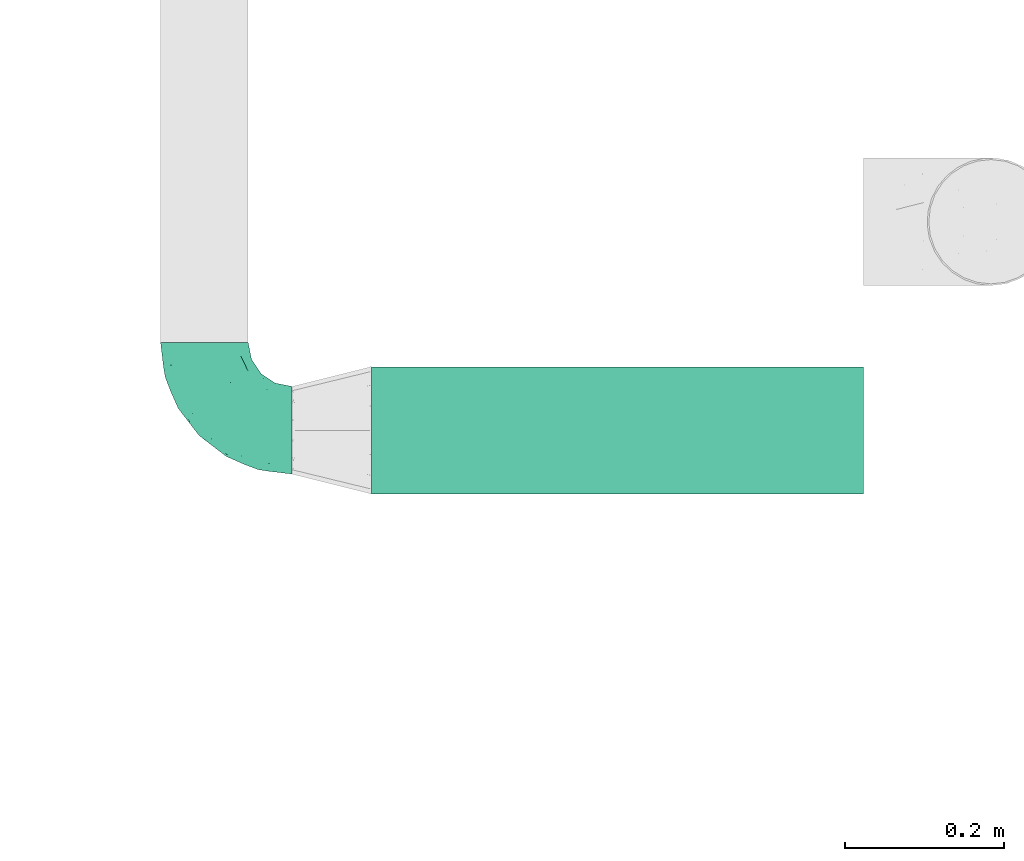
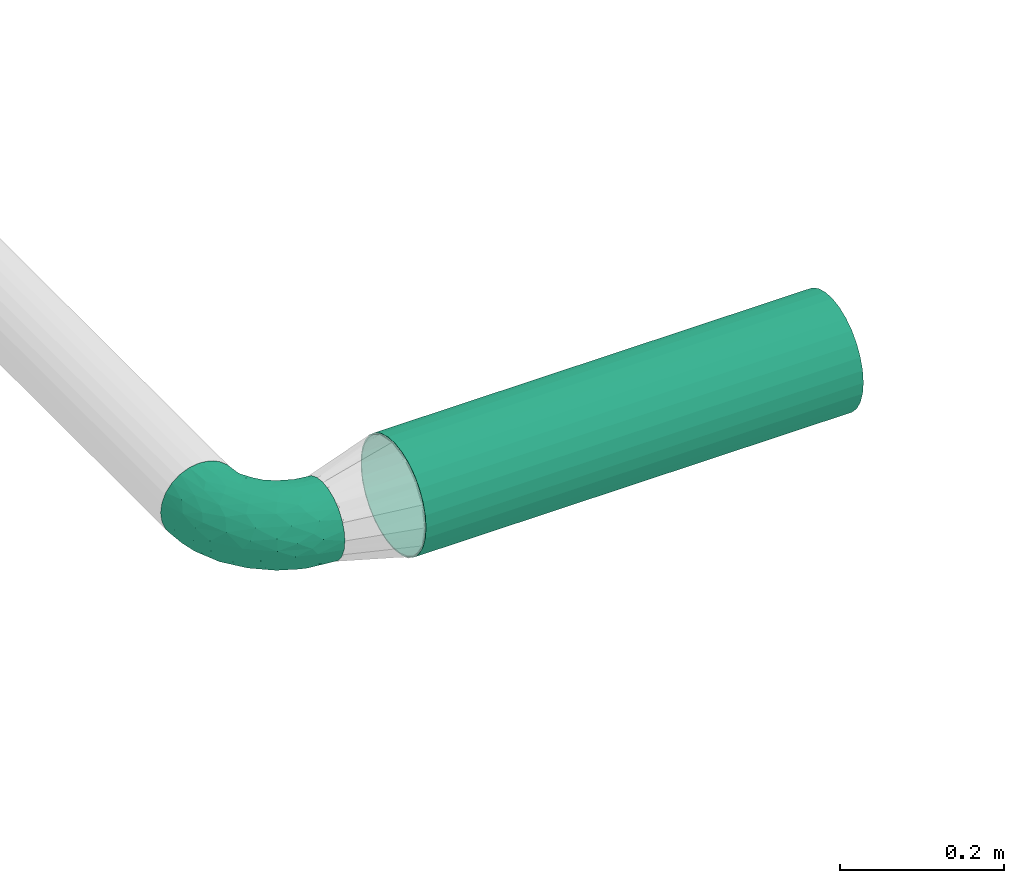
# One storey, part 107 of 123: 1 flow fitting, 1 flow segment.
"""IFC2X3 building model written with IfcOpenShell, lengths in millimetres."""

from ifc_helpers import new_model, entity, si_unit, converted_unit, derived_unit, direction, frame, origin_with_axes, origin_2d_with_axis, place, context, subcontext, project, spatial, hollow_circle, extrude, open_shell, surface_model, source, transform, mapped, material, layer, layer_set, layer_usage, type_object, element, save


model = new_model("IFC2X3")

# Units and contexts
model_context = context("Model", 3, precision=1e-05, world=origin_with_axes(), true_north=direction((0.0, 1.0)))
body_context = subcontext(model_context, "Body", "Model", "MODEL_VIEW")
ifc_project = project(units=[si_unit("AREAUNIT", "SQUARE_METRE"), si_unit("VOLUMEUNIT", "CUBIC_METRE", prefix="DECI"), si_unit("TIMEUNIT", "SECOND"), si_unit("THERMODYNAMICTEMPERATUREUNIT", "DEGREE_CELSIUS"), si_unit("PRESSUREUNIT", "PASCAL"), si_unit("MASSUNIT", "GRAM", prefix="KILO"), si_unit("LENGTHUNIT", "METRE", prefix="MILLI"), si_unit("POWERUNIT", "WATT"), si_unit("ELECTRICCURRENTUNIT", "AMPERE"), si_unit("ELECTRICVOLTAGEUNIT", "VOLT"), derived_unit("VOLUMETRICFLOWRATEUNIT", [(si_unit("VOLUMEUNIT", "CUBIC_METRE", prefix="DECI"), 1), (si_unit("TIMEUNIT", "SECOND"), -1)]), derived_unit("LINEARVELOCITYUNIT", [(si_unit("LENGTHUNIT", "METRE"), 1), (si_unit("TIMEUNIT", "SECOND"), -1)]), derived_unit("MASSDENSITYUNIT", [(si_unit("MASSUNIT", "GRAM", prefix="KILO"), 1), (si_unit("VOLUMEUNIT", "CUBIC_METRE"), -1)]), converted_unit("PLANEANGLEUNIT", "DEGREE", entity("IfcRatioMeasure", 0.01745), si_unit("PLANEANGLEUNIT", "RADIAN"), dimensions=[0, 0, 0, 0, 0, 0, 0])], contexts=[model_context])

# Site, building, storey
site_placement = place(None, origin_with_axes())
site = spatial("IfcSite", under=ifc_project, at=site_placement, CompositionType="ELEMENT")
building_placement = place(site_placement, origin_with_axes())
building = spatial("IfcBuilding", under=site, at=building_placement, Name="mc-building", CompositionType="ELEMENT")
storey_placement = place(building_placement, origin_with_axes())
storey = spatial("IfcBuildingStorey", under=building, at=storey_placement, Name="1. Korrus", CompositionType="ELEMENT", Elevation=0.0)

# Flow fitting
duct_fitting_type = type_object("IfcDuctFittingType", Name="BU", PredefinedType="BEND")
shared_shape_1 = source(origin_with_axes(), body_context, "Body", "SurfaceModel", [
    surface_model("IfcShellBasedSurfaceModel", [(-110.0, 0.0, -55.0), (-110.0, -14.23505, -53.12592), (-110.0, 14.23505, -53.12592), (-110.0, 53.12592, 14.23505), (-110.0, 27.5, -47.63139), (-110.0, 38.89087, -38.89087), (-110.0, -55.0, 0.0), (-110.0, -53.12592, 14.23505), (-110.0, -38.89087, -38.89087), (-110.0, -27.5, -47.63139), (-110.0, -53.12592, -14.23505), (-110.0, -47.63139, -27.5), (-110.0, -14.23505, 53.12592), (-110.0, 14.23505, 53.12592), (-110.0, 27.5, 47.63139), (-110.0, -47.63139, 27.5), (-110.0, -38.89087, 38.89087), (-110.0, -27.5, 47.63139), (-110.0, 0.0, 55.0), (-110.0, 55.0, 0.0), (-110.0, 53.12592, -14.23505), (-110.0, 47.63139, -27.5), (-110.0, 47.63139, 27.5), (-110.0, 38.89087, 38.89087), (-14.23505, 110.0, -53.12592), (-55.0, 110.0, 0.0), (0.0, 110.0, -55.0), (-27.5, 110.0, -47.63139), (-38.89087, 110.0, -38.89087), (-47.63139, 110.0, -27.5), (38.89087, 110.0, -38.89087), (53.12592, 110.0, 14.23505), (27.5, 110.0, -47.63139), (14.23505, 110.0, -53.12592), (47.63139, 110.0, -27.5), (53.12592, 110.0, -14.23505), (55.0, 110.0, 0.0), (-53.12592, 110.0, -14.23505), (-53.12592, 110.0, 14.23505), (-47.63139, 110.0, 27.5), (-38.89087, 110.0, 38.89087), (-27.5, 110.0, 47.63139), (0.0, 110.0, 55.0), (-14.23505, 110.0, 53.12592), (38.89087, 110.0, 38.89087), (47.63139, 110.0, 27.5), (27.5, 110.0, 47.63139), (14.23505, 110.0, 53.12592), (-64.21732, 48.68956, 43.63444), (-76.6405, 38.18013, 45.55988), (-60.44912, 32.56953, 51.94617), (-76.00813, 5.38378, 55.0), (-90.15553, 11.94394, 54.09138), (-78.5998, 26.77405, 50.81338), (-70.18771, 18.55163, 54.03432), (-75.55424, 54.2118, 32.41257), (-93.27622, 45.77614, 33.48188), (-96.12334, 22.13664, 50.81337), (-21.00813, 45.34362, 55.0), (-18.36258, 70.48427, 54.04484), (-32.04182, 59.64019, 52.24446), (-63.88653, 74.77858, 17.99134), (-74.66383, 63.08407, 19.92123), (-63.60674, 66.07878, 29.97482), (-99.597, 52.72185, 18.52927), (-93.11138, 56.59448, 10.50359), (-98.21577, 57.34403, 0.0), (-53.42855, 92.60092, 21.04759), (-88.54852, 54.8376, 21.04759), (-11.86161, 90.23965, 54.10313), (-5.38378, 76.00813, 55.0), (-57.34403, 98.21577, 0.0), (-56.64619, 93.12774, 10.22088), (-45.34362, 21.00813, 55.0), (-44.60838, 44.60838, 52.13415), (-92.68484, 35.46673, 43.63443), (-22.25266, 95.40765, 50.81337), (-35.97783, 90.61597, 43.63443), (-43.70931, 69.58671, 44.47149), (-27.23711, 77.39884, 50.81337), (-57.2828, 79.3123, 24.9774), (-58.67786, 84.31125, 16.04456), (-82.93277, 60.36161, 12.91784), (-49.88337, 54.51816, 47.224), (-74.57753, 66.83759, 9.55742), (-45.35812, 94.97281, 33.48188), (-59.18663, 88.95241, 0.0), (-51.517, 78.6292, 33.48188), (-65.14788, 80.03077, 0.0), (-56.45322, 62.06476, 39.63545), (-88.95241, 59.18663, 0.0), (-71.10913, 71.10913, 0.0), (-80.03077, 65.14788, 0.0), (-94.9309, 45.36788, -33.48188), (-93.11358, 56.60141, -10.46614), (-99.64997, 52.79499, -18.30015), (-90.20425, 36.08686, -43.63443), (-79.99933, 46.56772, -37.92748), (-76.00813, 5.38378, -55.0), (-72.75364, 19.68651, -53.60527), (-45.34362, 21.00813, -55.0), (-21.91957, 65.12078, -53.85897), (-5.38378, 76.00813, -55.0), (-21.00813, 45.34362, -55.0), (-35.41876, 92.89265, -43.63443), (-91.10309, 11.02766, -54.21832), (-45.77614, 93.27622, -33.48188), (-90.50474, 23.21022, -50.81337), (-70.92854, 33.31794, -49.51754), (-78.52933, 63.35627, -11.73997), (-24.91508, 84.05606, -50.81337), (-88.78941, 54.74452, -21.04759), (-69.59921, 57.34866, -33.48187), (-73.36422, 62.46673, -22.94182), (-63.49062, 67.59111, -28.46929), (-56.59448, 93.11138, -10.50359), (-54.8376, 88.54852, -21.04759), (-54.10679, 75.85581, -32.31867), (-57.75956, 31.09612, -52.80882), (-52.72185, 99.597, -18.52927), (-12.62913, 89.46304, -53.99097), (-34.46825, 66.46123, -50.04329), (-43.9837, 43.9837, -52.42279), (-65.78527, 72.58348, -17.68796), (-70.34468, 43.65295, -44.21951), (-57.47001, 51.99467, -44.91465), (-60.72547, 82.29174, -12.88567), (-42.34915, 74.24548, -43.63444), (-57.25194, 63.5016, -38.08211), (-80.95344, 53.56991, -29.32027), (-52.32891, 4.55257, -54.0482), (32.52942, 47.13398, -30.48571), (14.88266, 20.92917, -33.7947), (14.95561, 36.05775, -42.26543), (30.24048, 70.09027, -41.7461), (19.3559, 65.35825, -48.00507), (-70.35075, -46.44478, -19.5952), (-47.13398, -32.52942, -30.48571), (-28.49299, -30.5778, -16.4009), (-4.55257, 52.32891, -54.0482), (-22.4954, 22.4954, -53.25347), (-75.47368, -11.22546, -52.60718), (-81.32209, -51.5606, -9.98467), (-80.81763, -41.84862, -32.14655), (-70.09027, -30.24048, -41.7461), (-36.05774, -14.95561, -42.26543), (-9.15831, -10.852, -27.8997), (-65.35825, -19.3559, -48.00507), (11.22546, 75.47368, -52.60718), (3.94376, 43.9333, -50.53315), (-13.39742, 13.39743, -48.13058), (-43.9333, -3.94376, -50.53315), (49.37776, 67.29486, 0.0), (41.8609, 47.82256, -9.92641), (50.20582, 74.51695, -9.9731), (18.93131, 11.7156, -17.56239), (-27.5, -32.89419, 0.0), (-1.23348, -12.25375, -12.18106), (41.84862, 80.81763, -32.14655), (35.70604, 41.31408, -20.38235), (46.44478, 70.35075, -19.5952), (32.89419, 27.5, 0.0), (6.67262, -6.67262, 0.0), (-67.29486, -49.37776, 0.0), (-50.36265, -42.95545, -9.51562), (-5.47251, 5.47251, -39.92906), (-70.35075, -46.44478, 19.5952), (-74.51695, -50.20582, 9.9731), (-41.31407, -35.70604, 20.38235), (-47.13398, -32.52942, 30.48571), (-80.81763, -41.84862, 32.14655), (-4.55257, 52.32891, 54.0482), (11.22546, 75.47368, 52.60718), (-43.9333, -3.94376, 50.53315), (-65.35825, -19.3559, 48.00507), (-36.05774, -14.95561, 42.26543), (-70.09027, -30.24048, 41.7461), (-11.7156, -18.93131, 17.56239), (30.5778, 28.49299, 16.4009), (12.25375, 1.23348, 12.18106), (51.5606, 81.32209, 9.98467), (42.95545, 50.36265, 9.51562), (-75.47368, -11.22546, 52.60718), (-52.32891, 4.55257, 54.0482), (3.94376, 43.9333, 50.53315), (-22.4954, 22.4954, 53.25347), (-13.39742, 13.39743, 48.13058), (10.852, 9.15831, 27.8997), (-20.92916, -14.88266, 33.79469), (-47.82256, -41.8609, 9.92641), (32.52942, 47.13398, 30.48571), (46.44478, 70.35075, 19.5952), (41.84862, 80.81763, 32.14655), (30.24048, 70.09027, 41.7461), (19.3559, 65.35825, 48.00507), (14.95561, 36.05775, 42.26543), (-5.47251, 5.47251, 39.92906)], [open_shell([[[0, 1, 2]], [[2, 3, 4]], [[4, 3, 5]], [[2, 6, 7]], [[8, 6, 9]], [[1, 9, 6]], [[10, 6, 11]], [[8, 11, 6]], [[6, 2, 1]], [[12, 13, 14]], [[15, 2, 7]], [[16, 17, 2]], [[2, 17, 12]], [[12, 18, 13]], [[19, 20, 3]], [[5, 3, 21]], [[20, 21, 3]], [[22, 3, 2]], [[23, 22, 2]], [[12, 14, 2]], [[2, 14, 23]], [[15, 16, 2]], [[24, 25, 26]], [[27, 25, 24]], [[25, 28, 29]], [[28, 25, 27]], [[30, 26, 31]], [[26, 30, 32]], [[32, 33, 26]], [[34, 31, 35]], [[31, 34, 30]], [[35, 31, 36]], [[29, 37, 25]], [[38, 39, 26]], [[39, 40, 26]], [[41, 42, 40]], [[42, 26, 40]], [[42, 41, 43]], [[26, 44, 45]], [[31, 26, 45]], [[26, 46, 44]], [[47, 46, 26]], [[42, 47, 26]], [[25, 38, 26]], [[48, 49, 50]], [[18, 51, 52]], [[53, 54, 50]], [[55, 56, 49]], [[56, 22, 23]], [[13, 57, 14]], [[58, 59, 60]], [[61, 62, 63]], [[3, 64, 65]], [[53, 52, 54]], [[3, 65, 66]], [[67, 39, 38]], [[56, 68, 64]], [[65, 64, 68]], [[69, 59, 70]], [[38, 71, 72]], [[73, 58, 74]], [[75, 49, 56]], [[76, 69, 43]], [[53, 57, 52]], [[77, 78, 79]], [[41, 76, 43]], [[43, 69, 42]], [[55, 68, 56]], [[23, 14, 75]], [[76, 77, 79]], [[80, 67, 81]], [[62, 82, 68]], [[60, 78, 83]], [[62, 84, 82]], [[85, 77, 40]], [[81, 67, 72]], [[86, 72, 71]], [[87, 85, 67]], [[61, 81, 88]], [[77, 41, 40]], [[78, 77, 87]], [[23, 75, 56]], [[83, 89, 48]], [[85, 40, 39]], [[62, 68, 55]], [[89, 87, 63]], [[83, 48, 50]], [[57, 75, 14]], [[49, 75, 53]], [[67, 85, 39]], [[87, 77, 85]], [[63, 62, 55]], [[89, 55, 48]], [[80, 63, 87]], [[66, 65, 90]], [[66, 19, 3]], [[84, 91, 92]], [[92, 90, 82]], [[65, 82, 90]], [[61, 84, 62]], [[92, 82, 84]], [[68, 82, 65]], [[3, 22, 64]], [[56, 64, 22]], [[38, 25, 71]], [[81, 72, 86]], [[38, 72, 67]], [[91, 61, 88]], [[80, 81, 61]], [[63, 80, 61]], [[67, 80, 87]], [[77, 76, 41]], [[79, 59, 69]], [[79, 69, 76]], [[42, 69, 70]], [[60, 59, 79]], [[58, 70, 59]], [[78, 60, 79]], [[58, 60, 74]], [[52, 57, 13]], [[75, 57, 53]], [[18, 52, 13]], [[52, 51, 54]], [[51, 73, 54]], [[50, 73, 74]], [[73, 50, 54]], [[50, 74, 83]], [[60, 83, 74]], [[89, 83, 78]], [[87, 89, 78]], [[55, 89, 63]], [[50, 49, 53]], [[55, 49, 48]], [[81, 86, 88]], [[91, 84, 61]], [[5, 21, 93]], [[90, 94, 66]], [[20, 94, 95]], [[96, 93, 97]], [[98, 99, 100]], [[96, 4, 5]], [[101, 102, 103]], [[28, 27, 104]], [[2, 105, 0]], [[104, 106, 28]], [[99, 105, 107]], [[108, 107, 96]], [[90, 109, 94]], [[107, 2, 4]], [[20, 66, 94]], [[27, 24, 110]], [[109, 111, 94]], [[112, 113, 114]], [[37, 115, 71]], [[116, 106, 117]], [[99, 118, 100]], [[116, 115, 119]], [[37, 119, 115]], [[24, 120, 110]], [[121, 110, 101]], [[119, 106, 116]], [[101, 110, 120]], [[122, 103, 100]], [[117, 123, 116]], [[124, 125, 108]], [[115, 116, 126]], [[106, 29, 28]], [[26, 102, 120]], [[127, 104, 110]], [[97, 124, 96]], [[125, 122, 118]], [[128, 127, 125]], [[96, 5, 93]], [[115, 126, 86]], [[117, 106, 127]], [[111, 113, 129]], [[95, 93, 21]], [[97, 129, 112]], [[110, 104, 27]], [[106, 104, 127]], [[96, 107, 4]], [[99, 107, 108]], [[99, 108, 118]], [[105, 99, 98]], [[112, 114, 128]], [[121, 125, 127]], [[20, 19, 66]], [[109, 90, 92]], [[94, 111, 95]], [[91, 123, 109]], [[129, 113, 112]], [[93, 95, 111]], [[21, 20, 95]], [[71, 115, 86]], [[71, 25, 37]], [[123, 91, 88]], [[126, 116, 123]], [[123, 88, 126]], [[86, 126, 88]], [[37, 29, 119]], [[106, 119, 29]], [[129, 93, 111]], [[124, 112, 125]], [[0, 105, 98]], [[107, 105, 2]], [[125, 118, 108]], [[100, 118, 122]], [[93, 129, 97]], [[113, 111, 109]], [[109, 123, 113]], [[114, 123, 117]], [[123, 114, 113]], [[128, 114, 117]], [[127, 128, 117]], [[112, 128, 125]], [[103, 122, 101]], [[110, 121, 127]], [[101, 122, 121]], [[125, 121, 122]], [[26, 120, 24]], [[101, 120, 102]], [[96, 124, 108]], [[92, 91, 109]], [[112, 124, 97]], [[100, 130, 98]], [[131, 132, 133]], [[32, 134, 135]], [[136, 137, 138]], [[139, 140, 103]], [[98, 141, 0]], [[142, 10, 136]], [[143, 144, 137]], [[6, 10, 142]], [[137, 145, 146]], [[144, 147, 145]], [[143, 136, 11]], [[11, 136, 10]], [[8, 143, 11]], [[148, 149, 139]], [[8, 9, 144]], [[9, 1, 147]], [[130, 141, 98]], [[103, 140, 100]], [[148, 135, 149]], [[150, 151, 140]], [[152, 153, 154]], [[130, 140, 151]], [[148, 26, 33]], [[147, 1, 141]], [[155, 146, 132]], [[156, 138, 157]], [[134, 30, 158]], [[150, 140, 149]], [[158, 30, 34]], [[30, 134, 32]], [[153, 159, 160]], [[131, 160, 159]], [[144, 145, 137]], [[36, 152, 154]], [[146, 138, 137]], [[155, 161, 162]], [[158, 160, 131]], [[133, 149, 135]], [[156, 163, 164]], [[163, 142, 164]], [[139, 103, 102]], [[153, 152, 161]], [[34, 35, 160]], [[162, 157, 155]], [[132, 165, 133]], [[157, 146, 155]], [[140, 130, 100]], [[141, 130, 151]], [[141, 151, 147]], [[141, 1, 0]], [[102, 26, 148]], [[140, 139, 149]], [[102, 148, 139]], [[135, 33, 32]], [[151, 150, 145]], [[9, 147, 144]], [[151, 145, 147]], [[145, 165, 146]], [[135, 148, 33]], [[133, 135, 134]], [[131, 133, 134]], [[133, 165, 150]], [[133, 150, 149]], [[145, 150, 165]], [[132, 131, 159]], [[146, 165, 132]], [[160, 158, 34]], [[134, 158, 131]], [[144, 143, 8]], [[136, 143, 137]], [[155, 153, 161]], [[154, 153, 160]], [[153, 155, 159]], [[132, 159, 155]], [[160, 35, 154]], [[36, 154, 35]], [[164, 136, 138]], [[6, 142, 163]], [[136, 164, 142]], [[156, 164, 138]], [[156, 157, 162]], [[146, 157, 138]], [[15, 7, 166]], [[6, 163, 167]], [[168, 169, 166]], [[166, 169, 170]], [[171, 172, 70]], [[173, 174, 175]], [[17, 176, 174]], [[177, 156, 162]], [[176, 16, 170]], [[170, 16, 15]], [[161, 178, 179]], [[152, 180, 181]], [[182, 173, 183]], [[18, 12, 182]], [[184, 185, 186]], [[183, 185, 73]], [[183, 73, 51]], [[177, 187, 188]], [[189, 168, 166]], [[187, 178, 190]], [[16, 176, 17]], [[161, 152, 181]], [[45, 191, 31]], [[45, 44, 192]], [[192, 191, 45]], [[180, 36, 31]], [[193, 194, 195]], [[46, 47, 194]], [[193, 195, 190]], [[193, 44, 46]], [[172, 42, 70]], [[185, 58, 73]], [[189, 163, 156]], [[163, 189, 167]], [[70, 58, 171]], [[184, 171, 185]], [[169, 188, 175]], [[180, 31, 191]], [[192, 193, 190]], [[191, 190, 178]], [[182, 174, 173]], [[194, 47, 172]], [[190, 195, 187]], [[186, 185, 173]], [[162, 179, 177]], [[188, 196, 175]], [[179, 187, 177]], [[185, 171, 58]], [[172, 171, 184]], [[172, 184, 194]], [[172, 47, 42]], [[51, 18, 182]], [[185, 183, 173]], [[51, 182, 183]], [[174, 12, 17]], [[184, 186, 195]], [[46, 194, 193]], [[184, 195, 194]], [[195, 196, 187]], [[174, 182, 12]], [[175, 174, 176]], [[169, 175, 176]], [[175, 196, 186]], [[175, 186, 173]], [[195, 186, 196]], [[188, 169, 168]], [[187, 196, 188]], [[166, 170, 15]], [[176, 170, 169]], [[193, 192, 44]], [[191, 192, 190]], [[177, 189, 156]], [[167, 189, 166]], [[189, 177, 168]], [[188, 168, 177]], [[166, 7, 167]], [[6, 167, 7]], [[181, 191, 178]], [[36, 180, 152]], [[191, 181, 180]], [[161, 181, 178]], [[161, 179, 162]], [[187, 179, 178]]])]),
])
flow_fitting_placement = place(storey_placement, frame((36782.68931, 4601.38149, 2625.0), z_axis=(0.0, 0.0, 1.0), x_axis=(0.0, -1.0, 0.0)))
element("IfcFlowFitting", 1, at=flow_fitting_placement, inside=storey, type_object=duct_fitting_type, Name="BU", context=body_context, shape_type="MappedRepresentation", body=[
    mapped(shared_shape_1, transform((0.0, 0.0, 0.0), scale=1.0)),
])

# Flow segment
ifc_material = material(Name="FZ1")
ifc_layer = layer(ifc_material, 0.0)
ifc_layer_set = layer_set([ifc_layer], Name="FZ1")
ifc_layer_usage = layer_usage(ifc_layer_set, "AXIS1", "POSITIVE", 0.0)
duct_segment_type = type_object("IfcDuctSegmentType", PredefinedType="RIGIDSEGMENT")
shared_shape_2 = source(origin_with_axes(), body_context, "Body", "SweptSolid", [
    extrude(hollow_circle(Radius=80.0, WallThickness=2.0, at=origin_2d_with_axis()), frame((0.0, 0.0, 0.0), z_axis=(1.0, 0.0, 0.0), x_axis=(0.0, 1.0, 0.0)), (0.0, 0.0, 1.0), 617.3),
])
flow_segment_placement = place(storey_placement, frame((37609.98441, 4601.38149, 2625.0), z_axis=(0.0, 0.0, 1.0), x_axis=(-1.0, 0.0, 0.0)))
element("IfcFlowSegment", 2, at=flow_segment_placement, inside=storey, type_object=duct_segment_type, material=ifc_layer_usage, context=body_context, shape_type="MappedRepresentation", body=[
    mapped(shared_shape_2, transform((0.0, 0.0, 0.0), scale=1.0)),
])

save(model, "model.ifc")
